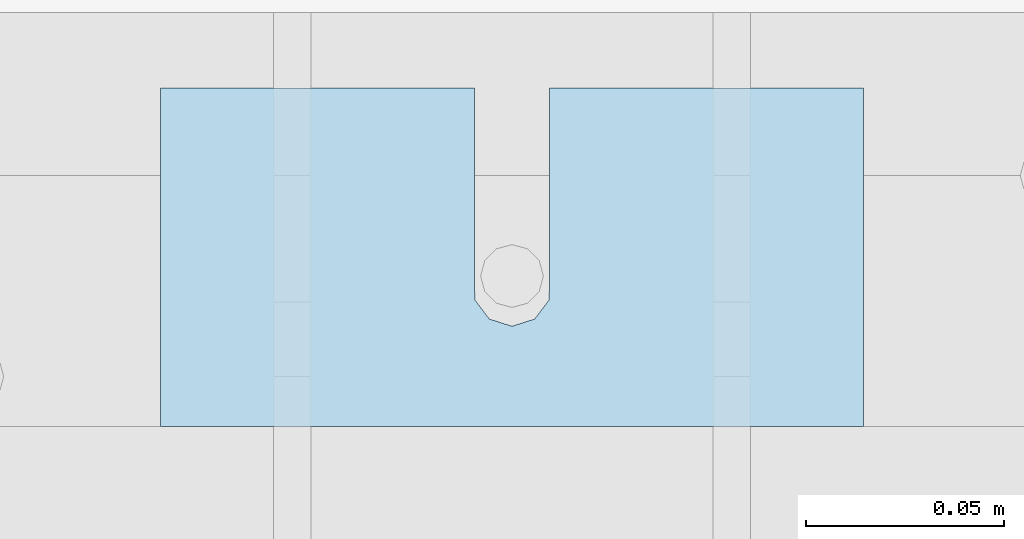
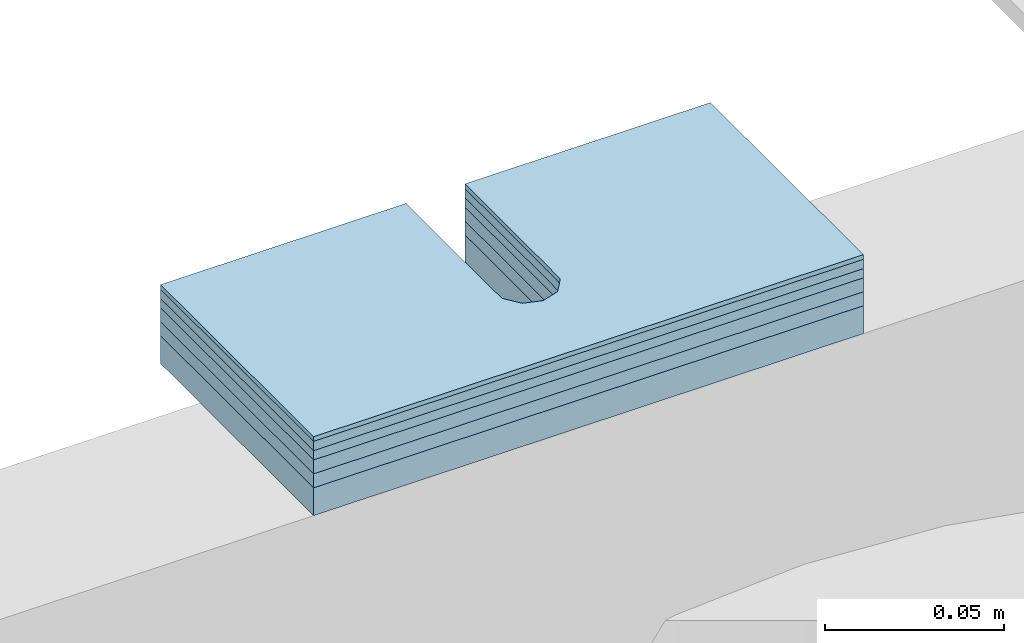
# One storey, part 1750 of 1876: 6 plates, 6 elements without a shape of their own.
"""IFC2X3 building model written with IfcOpenShell, lengths in millimetres."""

from ifc_helpers import new_model, si_unit, frame, origin_with_axes, place, context, subcontext, project, spatial, faceted_brep, material, type_object, element, aggregate, save


model = new_model("IFC2X3")

# Units and contexts
model_context = context("Model", 3, precision=1e-05, world=origin_with_axes())
body_context = subcontext(model_context, "Body", "Model", "MODEL_VIEW")
ifc_project = project(units=[si_unit("LENGTHUNIT", "METRE", prefix="MILLI"), si_unit("AREAUNIT", "SQUARE_METRE"), si_unit("VOLUMEUNIT", "CUBIC_METRE"), si_unit("MASSUNIT", "GRAM", prefix="KILO"), si_unit("TIMEUNIT", "SECOND"), si_unit("PLANEANGLEUNIT", "RADIAN"), si_unit("SOLIDANGLEUNIT", "STERADIAN"), si_unit("THERMODYNAMICTEMPERATUREUNIT", "DEGREE_CELSIUS"), si_unit("LUMINOUSINTENSITYUNIT", "LUMEN")], contexts=[model_context])

# Site, building, storey
site_placement = place(None, origin_with_axes())
site = spatial("IfcSite", under=ifc_project, at=site_placement, CompositionType="ELEMENT")
building_placement = place(site_placement, origin_with_axes())
building = spatial("IfcBuilding", under=site, at=building_placement, Name="Undefined", CompositionType="ELEMENT")
storey_placement = place(building_placement, origin_with_axes())
storey = spatial("IfcBuildingStorey", under=building, at=storey_placement, Name="Undefined", CompositionType="ELEMENT", Elevation=0.0)

# Assembly, plate
assembly_1_placement = place(storey_placement, origin_with_axes())
assembly_1 = element("IfcElementAssembly", 1, at=assembly_1_placement, inside=storey, Name="SHIM PLATE", AssemblyPlace="NOTDEFINED", PredefinedType="RIGID_FRAME")
ifc_material = material(Name="STEEL/A36")
plate_type_1 = type_object("IfcPlateType", PredefinedType="NOTDEFINED")
plate_1_placement = place(assembly_1_placement, frame((546.102974888169, 11880.850210959, 17987.9625), z_axis=(-1.18599999689195e-06, 0.999999999999297, 0.0), x_axis=(-0.999999999999297, -1.1859999968559e-06, 0.0)))
plate_1 = element("IfcPlate", 2, at=plate_1_placement, type_object=plate_type_1, material=ifc_material, Name="SHIM PLATE", context=body_context, shape_type="Brep", body=[
    faceted_brep([(79.3771379778037, -4.76250000000073, 85.7271118165263), (79.37941579775, -4.76250000000073, 38.1018605431018), (79.37941579775, 4.76250000000073, 38.1018605431018), (79.3771379778037, 4.76250000000073, 85.7271118165263), (79.5321553344801, -4.76250000000073, 32.0673270398438), (79.5321553344801, 4.76250000000073, 32.0673270398438), (83.1540408125562, -4.76250000000073, 27.2381584207487), (83.1540408125562, 4.76250000000073, 27.2381584207487), (88.9044302925666, -4.76250000000073, 25.4018728231113), (88.9044302925666, 4.76250000000073, 25.4018728231113), (94.6548154736501, -4.76250000000073, 27.2381718829492), (94.6548154736501, 4.76250000000073, 27.2381718829492), (98.2766896461945, -4.76250000000073, 32.067348981207), (98.2766896461945, 4.76250000000073, 32.067348981207), (98.429415055534, -4.76250000000073, 38.1018828420274), (98.429415055534, 4.76250000000073, 38.1018828420274), (98.4271372355728, -4.76250000000073, 85.7271231135492), (98.4271372355727, 4.76250000000073, 85.727111816539), (0.0, -4.76249999999982, 0.0), (0.00274557596708291, -4.76250000000073, 85.7271118164699), (0.00274557596708291, 4.76250000000073, 85.7271118164699), (0.0, 4.76249999999982, 0.0), (177.801635742191, -4.76250000000073, 1.21872290037572e-10), (177.801635742191, 4.76250000000073, 1.21872290037572e-10), (177.801528930665, -4.76250000000073, 85.7271118165972), (177.801528930665, 4.76250000000073, 85.7271118165972)], [[[0, 1, 2, 3]], [[4, 5, 2, 1]], [[6, 7, 5, 4]], [[8, 9, 7, 6]], [[10, 11, 9, 8]], [[12, 13, 11, 10]], [[14, 15, 13, 12]], [[16, 17, 15, 14]], [[18, 19, 20, 21]], [[22, 18, 21, 23]], [[24, 22, 23, 25]], [[12, 10, 8, 6, 4, 1, 0, 19, 18, 22, 24, 16, 14]], [[20, 19, 0, 3]], [[25, 23, 21, 20, 3, 2, 5, 7, 9, 11, 13, 15, 17]], [[24, 25, 17, 16]]]),
])
aggregate(assembly_1, [plate_1])

assembly_2_placement = place(storey_placement, origin_with_axes())
assembly_2 = element("IfcElementAssembly", 3, at=assembly_2_placement, inside=storey, Name="SHIM PLATE", AssemblyPlace="NOTDEFINED", PredefinedType="RIGID_FRAME")
plate_type_2 = type_object("IfcPlateType", PredefinedType="NOTDEFINED")
plate_2_placement = place(assembly_2_placement, frame((546.102974888207, 11880.8502109578, 18009.3925), z_axis=(-1.18599999689195e-06, 0.999999999999297, 0.0), x_axis=(-0.999999999999297, -1.1859999968559e-06, 0.0)))
plate_2 = element("IfcPlate", 4, at=plate_2_placement, type_object=plate_type_2, material=ifc_material, Name="SHIM PLATE", context=body_context, shape_type="Brep", body=[
    faceted_brep([(79.3771379778037, -0.793499999999767, 85.7271118165263), (79.37941579775, -0.793499999999767, 38.1018605431018), (79.37941579775, 0.793499999999767, 38.1018605431018), (79.3771379778037, 0.793499999999767, 85.7271118165263), (79.5321553344801, -0.793499999999767, 32.0673270398438), (79.5321553344801, 0.793499999999767, 32.0673270398438), (83.1540408125562, -0.793499999999767, 27.2381584207487), (83.1540408125562, 0.793499999999767, 27.2381584207487), (88.9044302925666, -0.793499999999767, 25.4018728231113), (88.9044302925666, 0.793499999999767, 25.4018728231113), (94.6548154736501, -0.793499999999767, 27.2381718829492), (94.6548154736501, 0.793499999999767, 27.2381718829492), (98.2766896461945, -0.793499999999767, 32.067348981207), (98.2766896461945, 0.793499999999767, 32.067348981207), (98.429415055534, -0.793499999999767, 38.1018828420274), (98.429415055534, 0.793499999999767, 38.1018828420274), (98.4271372355728, -0.793499999999767, 85.7271231135492), (98.4271372355727, 0.793499999999767, 85.727111816539), (9.09494701772928e-13, -0.793499999999767, 0.0), (0.00274557596708291, -0.793499999999767, 85.7271118164699), (0.00274557596708291, 0.793499999999767, 85.7271118164699), (9.09494701772928e-13, 0.793499999999767, 0.0), (177.801635742191, -0.793499999999767, 1.36424205265939e-10), (177.801635742191, 0.793499999999767, 1.36424205265939e-10), (177.801528930665, -0.793499999999767, 85.7271118165972), (177.801528930665, 0.793499999999767, 85.7271118165972)], [[[0, 1, 2, 3]], [[4, 5, 2, 1]], [[6, 7, 5, 4]], [[8, 9, 7, 6]], [[10, 11, 9, 8]], [[12, 13, 11, 10]], [[14, 15, 13, 12]], [[16, 17, 15, 14]], [[18, 19, 20, 21]], [[22, 18, 21, 23]], [[24, 22, 23, 25]], [[12, 10, 8, 6, 4, 1, 0, 19, 18, 22, 24, 16, 14]], [[20, 19, 0, 3]], [[25, 23, 21, 20, 3, 2, 5, 7, 9, 11, 13, 15, 17]], [[24, 25, 17, 16]]]),
])
aggregate(assembly_2, [plate_2])

assembly_3_placement = place(storey_placement, origin_with_axes())
assembly_3 = element("IfcElementAssembly", 5, at=assembly_3_placement, inside=storey, Name="SHIM PLATE", AssemblyPlace="NOTDEFINED", PredefinedType="RIGID_FRAME")
plate_type_3 = type_object("IfcPlateType", PredefinedType="NOTDEFINED")
plate_3_placement = place(assembly_3_placement, frame((546.102974888199, 11880.850210958, 18007.0115), z_axis=(-1.18599999689195e-06, 0.999999999999297, 0.0), x_axis=(-0.999999999999297, -1.1859999968559e-06, 0.0)))
plate_3 = element("IfcPlate", 6, at=plate_3_placement, type_object=plate_type_3, material=ifc_material, Name="SHIM PLATE", context=body_context, shape_type="Brep", body=[
    faceted_brep([(79.3771379778037, -1.58750000000146, 85.7271118165263), (79.37941579775, -1.58750000000146, 38.1018605431018), (79.37941579775, 1.58750000000146, 38.1018605431018), (79.3771379778037, 1.58750000000146, 85.7271118165263), (79.5321553344801, -1.58750000000146, 32.0673270398438), (79.5321553344801, 1.58750000000146, 32.0673270398438), (83.1540408125562, -1.58750000000146, 27.2381584207487), (83.1540408125562, 1.58750000000146, 27.2381584207487), (88.9044302925666, -1.58750000000146, 25.4018728231113), (88.9044302925666, 1.58750000000146, 25.4018728231113), (94.6548154736501, -1.58750000000146, 27.2381718829492), (94.6548154736501, 1.58750000000146, 27.2381718829492), (98.2766896461945, -1.58750000000146, 32.067348981207), (98.2766896461945, 1.58750000000146, 32.067348981207), (98.429415055534, -1.58750000000146, 38.1018828420274), (98.429415055534, 1.58750000000146, 38.1018828420274), (98.4271372355728, -1.58750000000146, 85.7271231135492), (98.4271372355727, 1.58750000000146, 85.727111816539), (9.09494701772928e-13, -1.58750000000146, 4.54747350886464e-13), (0.00274557596708291, -1.58750000000146, 85.7271118164699), (0.00274557596708291, 1.58750000000146, 85.7271118164699), (9.09494701772928e-13, 1.58750000000146, 4.54747350886464e-13), (177.801635742191, -1.58750000000146, 1.38243194669485e-10), (177.801635742191, 1.58750000000146, 1.38243194669485e-10), (177.801528930665, -1.58750000000146, 85.7271118165972), (177.801528930665, 1.58750000000146, 85.7271118165972)], [[[0, 1, 2, 3]], [[4, 5, 2, 1]], [[6, 7, 5, 4]], [[8, 9, 7, 6]], [[10, 11, 9, 8]], [[12, 13, 11, 10]], [[14, 15, 13, 12]], [[16, 17, 15, 14]], [[18, 19, 20, 21]], [[22, 18, 21, 23]], [[24, 22, 23, 25]], [[12, 10, 8, 6, 4, 1, 0, 19, 18, 22, 24, 16, 14]], [[20, 19, 0, 3]], [[25, 23, 21, 20, 3, 2, 5, 7, 9, 11, 13, 15, 17]], [[24, 25, 17, 16]]]),
])
aggregate(assembly_3, [plate_3])

assembly_4_placement = place(storey_placement, origin_with_axes())
assembly_4 = element("IfcElementAssembly", 7, at=assembly_4_placement, inside=storey, Name="SHIM PLATE", AssemblyPlace="NOTDEFINED", PredefinedType="RIGID_FRAME")
plate_4_placement = place(assembly_4_placement, frame((546.102974888193, 11880.8502109582, 18003.8365), z_axis=(-1.18599999689195e-06, 0.999999999999297, 0.0), x_axis=(-0.999999999999297, -1.1859999968559e-06, 0.0)))
plate_4 = element("IfcPlate", 8, at=plate_4_placement, type_object=plate_type_3, material=ifc_material, Name="SHIM PLATE", context=body_context, shape_type="Brep", body=[
    faceted_brep([(79.3771379778037, -1.58750000000146, 85.7271118165263), (79.37941579775, -1.58750000000146, 38.1018605431018), (79.37941579775, 1.58750000000146, 38.1018605431018), (79.3771379778037, 1.58750000000146, 85.7271118165263), (79.5321553344801, -1.58750000000146, 32.0673270398438), (79.5321553344801, 1.58750000000146, 32.0673270398438), (83.1540408125562, -1.58750000000146, 27.2381584207487), (83.1540408125562, 1.58750000000146, 27.2381584207487), (88.9044302925666, -1.58750000000146, 25.4018728231113), (88.9044302925666, 1.58750000000146, 25.4018728231113), (94.6548154736501, -1.58750000000146, 27.2381718829492), (94.6548154736501, 1.58750000000146, 27.2381718829492), (98.2766896461945, -1.58750000000146, 32.067348981207), (98.2766896461945, 1.58750000000146, 32.067348981207), (98.429415055534, -1.58750000000146, 38.1018828420274), (98.429415055534, 1.58750000000146, 38.1018828420274), (98.4271372355728, -1.58750000000146, 85.7271231135492), (98.4271372355727, 1.58750000000146, 85.727111816539), (9.09494701772928e-13, -1.58750000000146, 4.54747350886464e-13), (0.00274557596708291, -1.58750000000146, 85.7271118164699), (0.00274557596708291, 1.58750000000146, 85.7271118164699), (9.09494701772928e-13, 1.58750000000146, 4.54747350886464e-13), (177.801635742191, -1.58750000000146, 1.38243194669485e-10), (177.801635742191, 1.58750000000146, 1.38243194669485e-10), (177.801528930665, -1.58750000000146, 85.7271118165972), (177.801528930665, 1.58750000000146, 85.7271118165972)], [[[0, 1, 2, 3]], [[4, 5, 2, 1]], [[6, 7, 5, 4]], [[8, 9, 7, 6]], [[10, 11, 9, 8]], [[12, 13, 11, 10]], [[14, 15, 13, 12]], [[16, 17, 15, 14]], [[18, 19, 20, 21]], [[22, 18, 21, 23]], [[24, 22, 23, 25]], [[12, 10, 8, 6, 4, 1, 0, 19, 18, 22, 24, 16, 14]], [[20, 19, 0, 3]], [[25, 23, 21, 20, 3, 2, 5, 7, 9, 11, 13, 15, 17]], [[24, 25, 17, 16]]]),
])
aggregate(assembly_4, [plate_4])

assembly_5_placement = place(storey_placement, origin_with_axes())
assembly_5 = element("IfcElementAssembly", 9, at=assembly_5_placement, inside=storey, Name="SHIM PLATE", AssemblyPlace="NOTDEFINED", PredefinedType="RIGID_FRAME")
plate_type_4 = type_object("IfcPlateType", PredefinedType="NOTDEFINED")
plate_5_placement = place(assembly_5_placement, frame((546.102974888188, 11880.8502109585, 17999.868), z_axis=(-1.18599999689195e-06, 0.999999999999297, 0.0), x_axis=(-0.999999999999297, -1.1859999968559e-06, 0.0)))
plate_5 = element("IfcPlate", 10, at=plate_5_placement, type_object=plate_type_4, material=ifc_material, Name="SHIM PLATE", context=body_context, shape_type="Brep", body=[
    faceted_brep([(79.3771379778037, -2.38100000000122, 85.7271118165263), (79.37941579775, -2.38100000000122, 38.1018605431018), (79.37941579775, 2.38100000000122, 38.1018605431018), (79.3771379778037, 2.38100000000122, 85.7271118165263), (79.5321553344801, -2.38100000000122, 32.0673270398438), (79.5321553344801, 2.38100000000122, 32.0673270398438), (83.1540408125562, -2.38100000000122, 27.2381584207487), (83.1540408125562, 2.38100000000122, 27.2381584207487), (88.9044302925666, -2.38100000000122, 25.4018728231113), (88.9044302925666, 2.38100000000122, 25.4018728231113), (94.6548154736501, -2.38100000000122, 27.2381718829492), (94.6548154736501, 2.38100000000122, 27.2381718829492), (98.2766896461945, -2.38100000000122, 32.067348981207), (98.2766896461945, 2.38100000000122, 32.067348981207), (98.429415055534, -2.38100000000122, 38.1018828420274), (98.429415055534, 2.38100000000122, 38.1018828420274), (98.4271372355728, -2.38100000000122, 85.7271231135492), (98.4271372355727, 2.38100000000122, 85.727111816539), (0.0, -2.38100000000122, 4.54747350886464e-13), (0.00274557596708291, -2.38100000000122, 85.7271118164699), (0.00274557596708291, 2.38100000000122, 85.7271118164699), (0.0, 2.38100000000122, 4.54747350886464e-13), (177.801635742191, -2.38100000000122, 1.20053300634027e-10), (177.801635742191, 2.38100000000122, 1.20053300634027e-10), (177.801528930665, -2.38100000000122, 85.7271118165972), (177.801528930665, 2.38100000000122, 85.7271118165972)], [[[0, 1, 2, 3]], [[4, 5, 2, 1]], [[6, 7, 5, 4]], [[8, 9, 7, 6]], [[10, 11, 9, 8]], [[12, 13, 11, 10]], [[14, 15, 13, 12]], [[16, 17, 15, 14]], [[18, 19, 20, 21]], [[22, 18, 21, 23]], [[24, 22, 23, 25]], [[12, 10, 8, 6, 4, 1, 0, 19, 18, 22, 24, 16, 14]], [[20, 19, 0, 3]], [[25, 23, 21, 20, 3, 2, 5, 7, 9, 11, 13, 15, 17]], [[24, 25, 17, 16]]]),
])
aggregate(assembly_5, [plate_5])

assembly_6_placement = place(storey_placement, origin_with_axes())
assembly_6 = element("IfcElementAssembly", 11, at=assembly_6_placement, inside=storey, Name="SHIM PLATE", AssemblyPlace="NOTDEFINED", PredefinedType="RIGID_FRAME")
plate_6_placement = place(assembly_6_placement, frame((546.102974888179, 11880.8502109587, 17995.106), z_axis=(-1.18599999689195e-06, 0.999999999999297, 0.0), x_axis=(-0.999999999999297, -1.1859999968559e-06, 0.0)))
plate_6 = element("IfcPlate", 12, at=plate_6_placement, type_object=plate_type_4, material=ifc_material, Name="SHIM PLATE", context=body_context, shape_type="Brep", body=[
    faceted_brep([(79.3771379778037, -2.38100000000122, 85.7271118165263), (79.37941579775, -2.38100000000122, 38.1018605431018), (79.37941579775, 2.38100000000122, 38.1018605431018), (79.3771379778037, 2.38100000000122, 85.7271118165263), (79.5321553344801, -2.38100000000122, 32.0673270398438), (79.5321553344801, 2.38100000000122, 32.0673270398438), (83.1540408125562, -2.38100000000122, 27.2381584207487), (83.1540408125562, 2.38100000000122, 27.2381584207487), (88.9044302925666, -2.38100000000122, 25.4018728231113), (88.9044302925666, 2.38100000000122, 25.4018728231113), (94.6548154736501, -2.38100000000122, 27.2381718829492), (94.6548154736501, 2.38100000000122, 27.2381718829492), (98.2766896461945, -2.38100000000122, 32.067348981207), (98.2766896461945, 2.38100000000122, 32.067348981207), (98.429415055534, -2.38100000000122, 38.1018828420274), (98.429415055534, 2.38100000000122, 38.1018828420274), (98.4271372355728, -2.38100000000122, 85.7271231135492), (98.4271372355727, 2.38100000000122, 85.727111816539), (0.0, -2.38100000000122, 4.54747350886464e-13), (0.00274557596708291, -2.38100000000122, 85.7271118164699), (0.00274557596708291, 2.38100000000122, 85.7271118164699), (0.0, 2.38100000000122, 4.54747350886464e-13), (177.801635742191, -2.38100000000122, 1.20053300634027e-10), (177.801635742191, 2.38100000000122, 1.20053300634027e-10), (177.801528930665, -2.38100000000122, 85.7271118165972), (177.801528930665, 2.38100000000122, 85.7271118165972)], [[[0, 1, 2, 3]], [[4, 5, 2, 1]], [[6, 7, 5, 4]], [[8, 9, 7, 6]], [[10, 11, 9, 8]], [[12, 13, 11, 10]], [[14, 15, 13, 12]], [[16, 17, 15, 14]], [[18, 19, 20, 21]], [[22, 18, 21, 23]], [[24, 22, 23, 25]], [[12, 10, 8, 6, 4, 1, 0, 19, 18, 22, 24, 16, 14]], [[20, 19, 0, 3]], [[25, 23, 21, 20, 3, 2, 5, 7, 9, 11, 13, 15, 17]], [[24, 25, 17, 16]]]),
])
aggregate(assembly_6, [plate_6])

save(model, "model.ifc")
